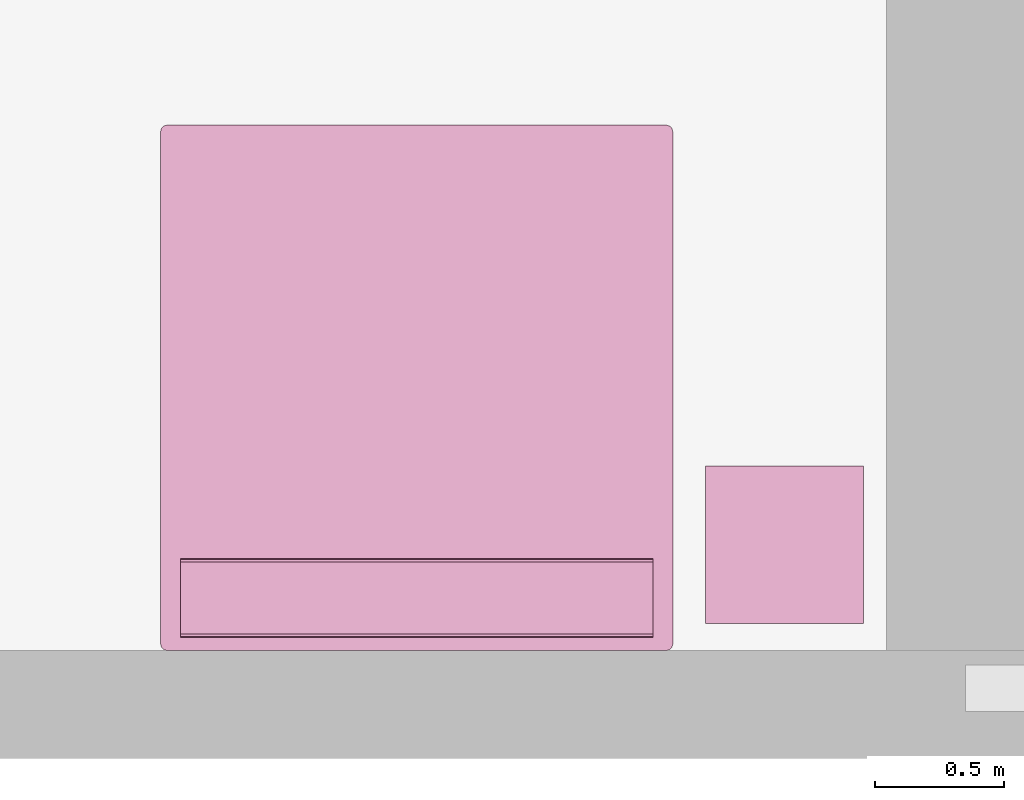
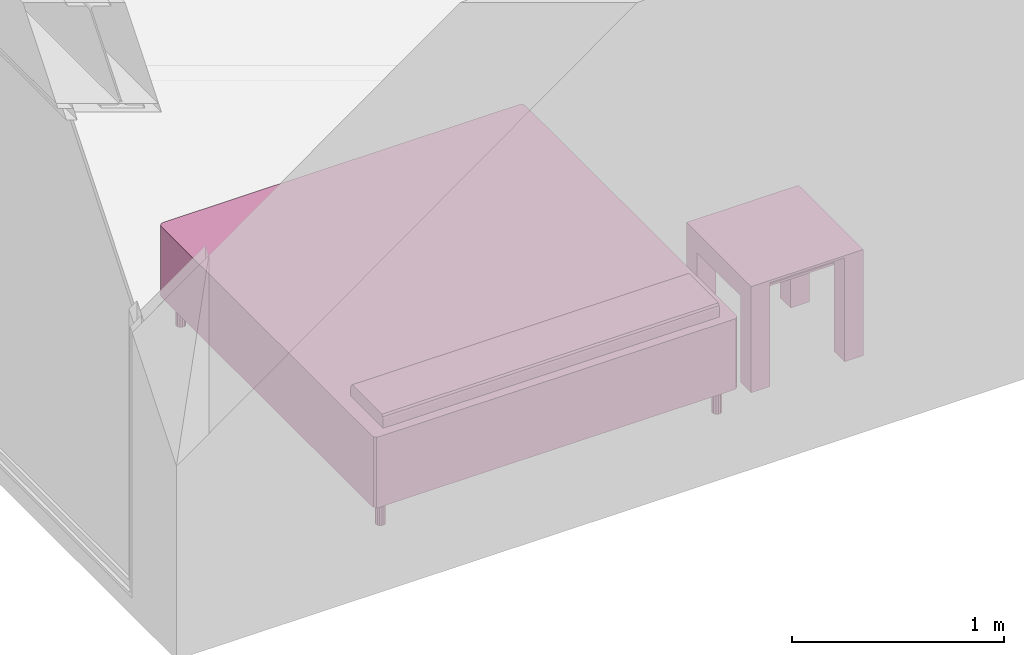
# One storey, part 6 of 12: 2 furnishings.
"""IFC2X3 building model written with IfcOpenShell, lengths in metres."""

import ifcopenshell
import ifcopenshell.guid

model = None  # the IFC model being written
_history = None  # IfcOwnerHistory: only IFC2X3 demands one
_inside = {}  # id of a spatial element -> (the spatial element, [elements in it])
_under = {}  # id of a project, library or spatial element -> (it, [spatial elements below it])
_declared = {}  # id of a project -> (the project, [libraries it declares])
_typed = {}  # id of a type object -> (the type object, [elements of that type])
_made_of = {}  # id of a material, layer set ... -> (it, [elements and type objects made of it])


def new_model(schema):
    """Start an empty IFC model of exactly this schema.

    Asked for "IFC4X3", IfcOpenShell would pick the latest addendum, in which some entities
    have other attributes; the version numbers below select the first issue.
    IFC2X3 requires an IfcOwnerHistory on every rooted entity: one is made here for all.
    """
    global model, _history
    if schema == "IFC4X3":
        model = ifcopenshell.file(schema_version=(4, 3, 0, 0))
    else:
        model = ifcopenshell.file(schema=schema)
    _inside.clear()
    _under.clear()
    _declared.clear()
    _typed.clear()
    _made_of.clear()
    _history = None
    if model.schema == "IFC2X3":
        org = make("IfcOrganization", Name="unknown")
        user = make(
            "IfcPersonAndOrganization",
            ThePerson=make("IfcPerson", FamilyName="unknown"),
            TheOrganization=org,
        )
        app = make(
            "IfcApplication",
            ApplicationDeveloper=org,
            Version="unknown",
            ApplicationFullName="unknown",
            ApplicationIdentifier="unknown",
        )
        _history = make(
            "IfcOwnerHistory",
            OwningUser=user,
            OwningApplication=app,
            ChangeAction="ADDED",
            CreationDate=0,
        )
    return model


def make(cls, **values):
    """One entity of the class cls with the attributes given. An attribute that is None is left unset."""
    return model.create_entity(
        cls, **{name: value for name, value in values.items() if value is not None}
    )


def entity(cls, *values):
    """Any entity or typed value of the class cls, its attributes in the order of the schema. None: left unset."""
    e = model.create_entity(cls)
    for i, value in enumerate(values):
        if value is not None:
            e[i] = value
    return e


def rooted(cls, **values):
    """An entity with a GlobalId (a new one), such as an element, a storey or a relation."""
    return make(cls, GlobalId=ifcopenshell.guid.new(), OwnerHistory=_history, **values)


def si_unit(unit_type, name, prefix=None):
    """IfcSIUnit, for example si_unit("LENGTHUNIT", "METRE", prefix="MILLI")."""
    return make("IfcSIUnit", UnitType=unit_type, Prefix=prefix, Name=name)


def converted_unit(unit_type, name, factor, base, dimensions=None, offset=None):
    """IfcConversionBasedUnit, such as the inch: factor (a typed value) times the base unit."""
    return make(
        "IfcConversionBasedUnit"
        if offset is None
        else "IfcConversionBasedUnitWithOffset",
        ConversionOffset=offset,
        Dimensions=None
        if dimensions is None
        else entity("IfcDimensionalExponents", *dimensions),
        UnitType=unit_type,
        Name=name,
        ConversionFactor=make(
            "IfcMeasureWithUnit", ValueComponent=factor, UnitComponent=base
        ),
    )


def assignment(units):
    """IfcUnitAssignment: the units of a project."""
    return None if units is None else make("IfcUnitAssignment", Units=units)


def point(xyz):
    """IfcCartesianPoint."""
    return None if xyz is None else make("IfcCartesianPoint", Coordinates=xyz)


def direction(xyz):
    """IfcDirection."""
    return None if xyz is None else make("IfcDirection", DirectionRatios=xyz)


def frame(location, z_axis=None, x_axis=None):
    """IfcAxis2Placement3D, a coordinate frame: its origin and axes. An axis left out is left unset."""
    return make(
        "IfcAxis2Placement3D",
        Location=point(location),
        Axis=direction(z_axis),
        RefDirection=direction(x_axis),
    )


def frame_2d(location, x_axis=None):
    """IfcAxis2Placement2D, a coordinate frame in the plane: its origin and x axis."""
    return make(
        "IfcAxis2Placement2D", Location=point(location), RefDirection=direction(x_axis)
    )


def origin():
    """The frame at (0, 0, 0) with its axes left unset."""
    return frame((0.0, 0.0, 0.0))


def origin_2d_with_axis():
    """The frame at (0, 0) in the plane with the x axis (1, 0) written out."""
    return frame_2d((0.0, 0.0), x_axis=(1.0, 0.0))


def place(relative_to, where):
    """IfcLocalPlacement: puts the frame where relative to a parent placement (None: the world)."""
    return make(
        "IfcLocalPlacement", PlacementRelTo=relative_to, RelativePlacement=where
    )


def context(
    kind, dimensions, precision=None, world=None, true_north=None, identifier=None
):
    """IfcGeometricRepresentationContext, for example the 3D "Model" context."""
    return make(
        "IfcGeometricRepresentationContext",
        ContextIdentifier=identifier,
        ContextType=kind,
        CoordinateSpaceDimension=dimensions,
        Precision=precision,
        WorldCoordinateSystem=world,
        TrueNorth=true_north,
    )


def project(units=None, contexts=None):
    """IfcProject with its units and contexts."""
    return rooted(
        "IfcProject",
        Name="project",
        RepresentationContexts=contexts,
        UnitsInContext=assignment(units),
    )


def spatial(cls, under=None, at=None, **own):
    """A site, building, storey or space (cls), placed at a placement, below another one or the project."""
    s = rooted(cls, ObjectPlacement=at, **own)
    if under is not None:
        _under.setdefault(under.id(), (under, []))[1].append(s)
    return s


def polyline(points):
    """IfcPolyline through the points."""
    return make("IfcPolyline", Points=[point(p) for p in points])


def profile(cls, at=None, kind="AREA", **sizes):
    """A parametric profile (cls). Its sizes go by their IFC names, for example OverallWidth=200.0."""
    return make(cls, ProfileType=kind, Position=at, **sizes)


def rectangle(**sizes):
    """IfcRectangleProfileDef."""
    return profile("IfcRectangleProfileDef", **sizes)


def outline(outer, holes=None, kind="AREA"):
    """IfcArbitraryClosedProfileDef: a profile drawn as a closed curve; with holes, ...WithVoids."""
    if holes is None:
        return make("IfcArbitraryClosedProfileDef", ProfileType=kind, OuterCurve=outer)
    return make(
        "IfcArbitraryProfileDefWithVoids",
        ProfileType=kind,
        OuterCurve=outer,
        InnerCurves=holes,
    )


def extrude(swept, where, along, depth):
    """IfcExtrudedAreaSolid: the profile swept, set in the frame where, extruded along a direction by depth."""
    return make(
        "IfcExtrudedAreaSolid",
        SweptArea=swept,
        Position=where,
        ExtrudedDirection=direction(along),
        Depth=depth,
    )


def faces_of(points, faces, orient=None, outer=None):
    """IfcFace entities. A face is a list of loops; a loop is a list of indices into points, from 0.

    orient and outer hold one flag for each loop. By default every Orientation is true, the
    first loop of a face is its IfcFaceOuterBound and the others are IfcFaceBound.
    """
    made = []
    for i, loops in enumerate(faces):
        bounds = []
        for j, loop in enumerate(loops):
            is_outer = j == 0 if outer is None else outer[i][j]
            bounds.append(
                make(
                    "IfcFaceOuterBound" if is_outer else "IfcFaceBound",
                    Bound=make("IfcPolyLoop", Polygon=[points[k] for k in loop]),
                    Orientation=True if orient is None else orient[i][j],
                )
            )
        made.append(make("IfcFace", Bounds=bounds))
    return made


def face_set(faces, orient=None, outer=None):
    """The faces of one IfcConnectedFaceSet. surface_model builds it on its shared points."""
    return ("IfcConnectedFaceSet", faces, orient, outer)


def surface_model(cls, points, shells):
    """IfcFaceBasedSurfaceModel or IfcShellBasedSurfaceModel (cls): surfaces that need not close."""
    shared = [point(p) for p in points]
    made = [make(c, CfsFaces=faces_of(shared, fs, o, b)) for c, fs, o, b in shells]
    if cls == "IfcFaceBasedSurfaceModel":
        return make(cls, FbsmFaces=made)
    return make(cls, SbsmBoundary=made)


def shape(context_of_items, identifier, shape_type, items):
    """IfcShapeRepresentation: the items that make up one representation, for example the "Body"."""
    return make(
        "IfcShapeRepresentation",
        ContextOfItems=context_of_items,
        RepresentationIdentifier=identifier,
        RepresentationType=shape_type,
        Items=items,
    )


def source(mapping_origin, context_of_items, identifier, shape_type, items):
    """IfcRepresentationMap: a shape defined once, which mapped items show again and again."""
    return make(
        "IfcRepresentationMap",
        MappingOrigin=mapping_origin,
        MappedRepresentation=shape(context_of_items, identifier, shape_type, items),
    )


def transform(
    local_origin,
    x_axis=None,
    y_axis=None,
    z_axis=None,
    scale=None,
    scale2=None,
    scale3=None,
    uniform=True,
):
    """IfcCartesianTransformationOperator3D, or its non-uniform kind. x_axis, y_axis, z_axis: its Axis1, 2, 3."""
    if uniform:
        return make(
            "IfcCartesianTransformationOperator3D",
            Axis1=direction(x_axis),
            Axis2=direction(y_axis),
            LocalOrigin=point(local_origin),
            Scale=scale,
            Axis3=direction(z_axis),
        )
    return make(
        "IfcCartesianTransformationOperator3DnonUniform",
        Axis1=direction(x_axis),
        Axis2=direction(y_axis),
        LocalOrigin=point(local_origin),
        Scale=scale,
        Axis3=direction(z_axis),
        Scale2=scale2,
        Scale3=scale3,
    )


def mapped(mapping_source, mapping_target):
    """IfcMappedItem: shows the shape of a source again, moved by a transform."""
    return make(
        "IfcMappedItem", MappingSource=mapping_source, MappingTarget=mapping_target
    )


def made_of(thing, what):
    """Note that an element or type object is made of a material, layer set ...; save() writes the relation."""
    if what is not None:
        _made_of.setdefault(what.id(), (what, []))[1].append(thing)
    return thing


def type_object(cls, material=None, **own):
    """A type object (cls), such as IfcWallType, which elements share."""
    return made_of(rooted(cls, **own), material)


def type_shapes(of_type, sources):
    """Give a type object the sources (RepresentationMaps) that its elements show as mapped items."""
    of_type.RepresentationMaps = sources


def element(
    cls,
    number,
    at=None,
    inside=None,
    cuts=None,
    type_object=None,
    material=None,
    context=None,
    identifier="Body",
    shape_type=None,
    held_by="IfcProductDefinitionShape",
    body=None,
    shapes=None,
    **own,
):
    """One element of the class cls, such as IfcWall. Its Tag is "e" and its number.

    at: its placement. inside: the storey or other place that contains it. cuts: it is an
    opening in that element (IfcRelVoidsElement). A single representation is given by context,
    identifier, shape_type and body (its items); several are given by shapes. held_by: the class
    of the entity that holds the representations. save() writes the other relations.
    """
    e = rooted(cls, Tag="e%d" % number, ObjectPlacement=at, **own)
    if body is not None:
        shapes = [shape(context, identifier, shape_type, body)]
    if shapes is not None:
        e.Representation = make(held_by, Representations=shapes)
    if inside is not None:
        _inside.setdefault(inside.id(), (inside, []))[1].append(e)
    if cuts is not None:
        rooted(
            "IfcRelVoidsElement", RelatingBuildingElement=cuts, RelatedOpeningElement=e
        )
    if type_object is not None:
        _typed.setdefault(type_object.id(), (type_object, []))[1].append(e)
    return made_of(e, material)


def aggregate(whole, parts):
    """IfcRelAggregates: a whole, such as a stair, and the parts it consists of."""
    return rooted("IfcRelAggregates", RelatingObject=whole, RelatedObjects=parts)


def save(model, path):
    """Write the relations noted so far, then the file.

    IfcRelAggregates (storeys below a building ...), IfcRelContainedInSpatialStructure (elements
    in a storey), IfcRelDefinesByType, IfcRelAssociatesMaterial and IfcRelDeclares: one each for
    every whole, place, type object, material and project.
    """
    for whole, parts in _under.values():
        aggregate(whole, parts)
    for where, things in _inside.values():
        rooted(
            "IfcRelContainedInSpatialStructure",
            RelatedElements=things,
            RelatingStructure=where,
        )
    for kind, things in _typed.values():
        rooted("IfcRelDefinesByType", RelatedObjects=things, RelatingType=kind)
    for what, things in _made_of.values():
        rooted("IfcRelAssociatesMaterial", RelatedObjects=things, RelatingMaterial=what)
    for by, libraries in _declared.values():
        rooted("IfcRelDeclares", RelatingContext=by, RelatedDefinitions=libraries)
    model.write(path)


model = new_model("IFC2X3")

# Units and contexts
model_context = context("Model", 3, precision=1e-09, world=origin())
plan_context = context("Plan", 3, precision=1e-09, world=origin())
ifc_project = project(units=[si_unit("LENGTHUNIT", "METRE"), si_unit("AREAUNIT", "SQUARE_METRE"), si_unit("VOLUMEUNIT", "CUBIC_METRE"), converted_unit("PLANEANGLEUNIT", "DEGREE", entity("IfcRatioMeasure", 0.0174532925199433), si_unit("PLANEANGLEUNIT", "RADIAN"), dimensions=[0, 0, 0, 0, 0, 0, 0]), si_unit("TIMEUNIT", "SECOND")], contexts=[model_context, plan_context])

# Site, building, storey, space
site_placement = place(None, origin())
site = spatial("IfcSite", under=ifc_project, at=site_placement, CompositionType="ELEMENT")
building_placement = place(site_placement, origin())
building = spatial("IfcBuilding", under=site, at=building_placement, CompositionType="ELEMENT")
storey_placement = place(building_placement, frame((0.0, 0.0, 3.10000000000038)))
storey = spatial("IfcBuildingStorey", under=building, at=storey_placement, Name="Level 2", CompositionType="ELEMENT", Elevation=3.10000000000038)
space_placement = place(storey_placement, origin())
space = spatial("IfcSpace", under=storey, at=space_placement, CompositionType="ELEMENT", InteriorOrExteriorSpace="INTERNAL")

# Furnishings
furniture_type_1 = type_object("IfcFurnitureType", Name="0610 x 0610 x 0610mm", AssemblyPlace="NOTDEFINED")
shared_shape_1 = source(origin(), model_context, "Body", "SweptSolid", [
    extrude(rectangle(XDim=0.406799999999999, YDim=0.406799999999999, at=origin_2d_with_axis()), frame((0.0182657666726316, 0.0952110778022263, 0.4957), z_axis=(0.0, 0.0, 1.0), x_axis=(-1.0, 0.0, 0.0)), (0.0, 0.0, 1.0), 0.0127),
    extrude(outline(polyline([(-0.273249999999994, -0.305), (0.324049999999978, -0.305), (0.324049999999978, 0.304999999999998), (-0.273249999999993, 0.304999999999999), (-0.273249999999993, 0.203400000000001), (0.222450000000009, 0.203400000000001), (0.222450000000009, -0.2034), (-0.273249999999994, -0.2034), (-0.273249999999994, -0.305)])), frame((0.221665766672633, 0.0952110778022354, 0.273249999999992), z_axis=(1.0, 0.0, 0.0), x_axis=(0.0, 0.0, 1.0)), (0.0, 0.0, 1.0), 0.1016),
    extrude(outline(polyline([(-0.305000000000004, -0.324050000000025), (0.304999999999994, -0.324050000000025), (0.304999999999994, 0.273250000000011), (0.203400000000004, 0.273250000000011), (0.203400000000004, -0.222449999999996), (-0.203399999999995, -0.222449999999996), (-0.203399999999995, 0.273250000000011), (-0.305000000000004, 0.273250000000011), (-0.305000000000004, -0.324050000000025)])), frame((-0.286734233327367, 0.0952110778022256, 0.273250000000008), z_axis=(1.0, 0.0, 0.0), x_axis=(0.0, -1.0, 0.0)), (0.0, 0.0, 1.0), 0.1016),
    extrude(rectangle(XDim=0.406799999999999, YDim=0.406799999999999, at=origin_2d_with_axis()), frame((0.0182657666726316, 0.0952110778022259, 0.5973), z_axis=(0.0, 0.0, 1.0), x_axis=(-1.0, 0.0, 0.0)), (0.0, 0.0, 1.0), 0.0127),
    extrude(outline(polyline([(-0.305, -0.305000000000023), (0.305, -0.305000000000023), (0.305, 0.305000000000023), (-0.305, 0.305000000000023), (-0.305, -0.305000000000023)]), holes=[polyline([(-0.203399999999998, -0.203399999999975), (-0.203399999999998, 0.203400000000025), (0.203400000000001, 0.203400000000025), (0.203400000000001, -0.203399999999975), (-0.203399999999998, -0.203399999999975)])]), frame((0.0182657666726332, 0.0952110778022508, 0.5973), z_axis=(0.0, 0.0, 1.0), x_axis=(-1.0, 0.0, 0.0)), (0.0, 0.0, 1.0), 0.0127),
])
type_shapes(furniture_type_1, [shared_shape_1])
furnishing_1_placement = place(space_placement, frame((3.71173423332735, -17.0692110778022, 0.0189999999998181)))
element("IfcFurnishingElement", 1, at=furnishing_1_placement, inside=space, type_object=furniture_type_1, Name="M_Table-Coffee:0610 x 0610 x 0610mm:0610 x 0610 x 0610mm", ObjectType="0610 x 0610 x 0610mm", context=model_context, shape_type="MappedRepresentation", body=[
    mapped(shared_shape_1, transform((0.0, 0.0, 0.0), scale=1.0)),
])
furniture_type_2 = type_object("IfcFurnitureType", Name="1981 x 2032mm - King", AssemblyPlace="NOTDEFINED")
shared_shape_2 = source(origin(), model_context, "Body", "SurfaceModel", [
    surface_model("IfcFaceBasedSurfaceModel", [(0.00159527223592605, 0.0269952722359239, 0.3556), (0.00159527223591658, 2.00819527223598, 0.3556), (0.0049982269797851, 2.02089527223596, 0.3556), (0.0142952722358911, 2.03019231749206, 0.3556), (0.0269952722358653, 2.03359527223592, 0.3556), (1.95719527223595, 2.03359527223593, 0.3556), (1.96989527223593, 2.03019231749206, 0.3556), (1.97919231749203, 2.02089527223596, 0.3556), (1.98259527223589, 2.00819527223598, 0.3556), (1.9825952722359, 0.0269952722358916, 0.3556), (1.97919231749203, 0.0142952722359042, 0.3556), (1.96989527223591, 0.00499822697978862, 0.3556), (1.95719527223593, 0.00159527223592321, 0.3556), (0.0269952722359262, 0.00159527223592348, 0.3556), (0.0142952722359261, 0.0049982269797989, 0.3556), (0.00499822697980134, 0.0142952722359238, 0.3556), (0.00159527223592578, 0.0269952722359234, 0.1524), (0.00159527223591658, 2.00819527223598, 0.1524), (0.0049982269797851, 2.02089527223596, 0.1524), (0.0142952722358911, 2.03019231749206, 0.1524), (0.0269952722358655, 2.03359527223593, 0.1524), (1.95719527223595, 2.03359527223593, 0.1524), (1.96989527223593, 2.03019231749206, 0.1524), (1.97919231749203, 2.02089527223596, 0.1524), (1.9825952722359, 2.00819527223598, 0.1524), (1.9825952722359, 0.0269952722358916, 0.1524), (1.97919231749203, 0.0142952722359042, 0.1524), (1.96989527223591, 0.00499822697978862, 0.1524), (1.95719527223593, 0.00159527223591685, 0.1524), (0.0269952722359262, 0.00159527223592348, 0.1524), (0.0142952722359261, 0.0049982269797989, 0.1524), (0.00499822697980134, 0.0142952722359238, 0.1524), (0.00355996307916939, 0.0196629166603088, 0.152400001883507), (0.00329675246030092, 0.0206452682614327, 0.355599999427795), (0.00964672770351171, 0.00964673981070518, 0.355599999427795), (0.00964672770351171, 0.00964673981070518, 0.152400001883507), (0.0206452570855617, 0.00329676410183311, 0.152400001883507), (0.0196629054844379, 0.00355997472070157, 0.355599999427795), (1.96452760696411, 0.00355997472070157, 0.152400001883507), (1.96354532241821, 0.00329676410183311, 0.355599999427795), (1.97454369068146, 0.00964673981070518, 0.355599999427795), (1.97454369068146, 0.00964673981070518, 0.152400001883507), (1.98089373111725, 0.0206452682614327, 0.152400001883507), (1.98063051700592, 0.0196629166603088, 0.355599999427795), (1.98089373111725, 2.01454520225525, 0.355599999427795), (1.98089373111725, 2.01454520225525, 0.152400001883507), (1.97454369068146, 2.02554392814636, 0.355599999427795), (1.97454369068146, 2.02554392814636, 0.152400001883507), (1.96354532241821, 2.03189373016357, 0.152400001883507), (1.96452760696411, 2.03163051605225, 0.355599999427795), (0.0196629054844379, 2.03163051605225, 0.152400001883507), (0.0206452570855617, 2.03189373016357, 0.355599999427795), (0.00964672770351171, 2.02554392814636, 0.355599999427795), (0.00964672770351171, 2.02554392814636, 0.152400001883507), (0.00329675246030092, 2.01454520225525, 0.152400001883507), (0.00355996307916939, 2.01552772521973, 0.355599999427795), (0.0777952722359236, 1.67799527223594, 0.5588), (0.0777952722359236, 1.67799527223594, 0.6096), (0.0777952722359236, 1.68139822697982, 0.6223), (0.0777952722359236, 1.69069527223594, 0.631597045256125), (0.0777952722359236, 1.70339527223594, 0.635), (0.0777952722359242, 1.95739527223594, 0.635), (0.0777952722359242, 1.97009527223594, 0.631597045256125), (0.0777952722359242, 1.97939231749207, 0.6223), (0.0777952722359242, 1.98279527223594, 0.6096), (0.0777952722359242, 1.98279527223594, 0.5588), (1.90639527223589, 1.67799527223594, 0.5588), (1.9063952722359, 1.98279527223594, 0.5588), (1.9063952722359, 1.98279527223594, 0.6096), (1.9063952722359, 1.97939231749206, 0.6223), (1.9063952722359, 1.97009527223594, 0.631597045256125), (1.9063952722359, 1.95739527223594, 0.635), (1.90639527223589, 1.70339527223594, 0.635), (1.90639527223589, 1.69069527223594, 0.631597045256125), (1.90639527223589, 1.68139822697981, 0.6223), (1.90639527223589, 1.67799527223594, 0.6096), (0.0777952596545219, 1.67974185943603, 0.616118371486664), (1.90639531612396, 1.67969679832458, 0.615949988365173), (0.0777952596545219, 1.68604671955109, 0.626948475837708), (1.90639531612396, 1.68604671955109, 0.626948475837708), (1.90639531612396, 1.69704532623291, 0.633298575878143), (0.0777952596545219, 1.69687688350677, 0.633253455162048), (1.90639531612396, 1.96391367912293, 0.633253455162048), (0.0777952596545219, 1.96374523639679, 0.633298575878143), (0.0777952596545219, 1.97474384307861, 0.626948475837708), (1.90639531612396, 1.97474384307861, 0.626948475837708), (1.90639531612396, 1.98109376430511, 0.615949988365173), (0.0777952596545219, 1.98104870319366, 0.616118371486664), (0.1031952722359, 1.95739527223592, 0.1524), (0.100679881480621, 1.94637462526233, 0.1524), (0.0936319132031119, 1.93753675258123, 0.1524), (0.0834473039583905, 1.9326321032665, 0.1524), (0.0721432405134099, 1.9326321032665, 0.1524), (0.0619586312686885, 1.93753675258123, 0.1524), (0.0549106629911789, 1.94637462526233, 0.1524), (0.0523952722359002, 1.95739527223592, 0.1524), (0.0549106629911787, 1.9684159192095, 0.1524), (0.0619586312686883, 1.97725379189061, 0.1524), (0.0721432405134097, 1.98215844120534, 0.1524), (0.0834473039583904, 1.98215844120534, 0.1524), (0.0936319132031118, 1.97725379189061, 0.1524), (0.100679881480621, 1.9684159192095, 0.1524), (1.93179527223592, 1.95739527223595, 0.1524), (1.92927988148063, 1.94637462526236, 0.1524), (1.92223191320312, 1.93753675258125, 0.1524), (1.91204730395839, 1.93263210326651, 0.1524), (1.9007432405134, 1.93263210326651, 0.1524), (1.89055863126867, 1.93753675258125, 0.1524), (1.88351066299115, 1.94637462526236, 0.1524), (1.88099527223587, 1.95739527223595, 0.1524), (1.88351066299115, 1.96841591920955, 0.1524), (1.89055863126866, 1.97725379189066, 0.1524), (1.9007432405134, 1.98215844120539, 0.1524), (1.91204730395839, 1.98215844120539, 0.1524), (1.92223191320312, 1.97725379189066, 0.1524), (1.92927988148063, 1.96841591920955, 0.1524), (1.93179527223592, 0.0777952722359584, 0.1524), (1.92927988148064, 0.0667746252623723, 0.1524), (1.92223191320313, 0.0579367525812703, 0.1524), (1.91204730395841, 0.0530321032665399, 0.1524), (1.90074324051343, 0.0530321032665397, 0.1524), (1.8905586312687, 0.0579367525812703, 0.1524), (1.8835106629912, 0.0667746252623721, 0.1524), (1.88099527223592, 0.0777952722359579, 0.1524), (1.8835106629912, 0.0888159192095439, 0.1524), (1.8905586312687, 0.097653791890646, 0.1524), (1.90074324051343, 0.102558441205376, 0.1524), (1.91204730395841, 0.102558441205376, 0.1524), (1.92223191320313, 0.097653791890646, 0.1524), (1.92927988148064, 0.0888159192095439, 0.1524), (0.103195272235929, 0.0777952722359205, 0.1524), (0.10067988148065, 0.0667746252623334, 0.1524), (0.0936319132031394, 0.05793675258123, 0.1524), (0.0834473039584167, 0.053032103266499, 0.1524), (0.0721432405134344, 0.053032103266499, 0.1524), (0.0619586312687115, 0.0579367525812297, 0.1524), (0.0549106629912009, 0.0667746252623328, 0.1524), (0.0523952722359219, 0.0777952722359205, 0.1524), (0.0549106629912009, 0.0888159192095077, 0.1524), (0.0619586312687115, 0.0976537918906108, 0.1524), (0.0721432405134342, 0.102558441205342, 0.1524), (0.0834473039584165, 0.102558441205342, 0.1524), (0.0936319132031394, 0.0976537918906108, 0.1524), (0.10067988148065, 0.0888159192095077, 0.1524), (0.1031952722359, 1.95739527223592, 0.0), (0.100679881480621, 1.94637462526233, 0.0), (0.0936319132031119, 1.93753675258123, 0.0), (0.0834473039583905, 1.9326321032665, 0.0), (0.0721432405134099, 1.9326321032665, 0.0), (0.0619586312686885, 1.93753675258123, 0.0), (0.0549106629911789, 1.94637462526233, 0.0), (0.0523952722359002, 1.95739527223592, 0.0), (0.0549106629911787, 1.9684159192095, 0.0), (0.0619586312686883, 1.97725379189061, 0.0), (0.0721432405134097, 1.98215844120534, 0.0), (0.0834473039583904, 1.98215844120534, 0.0), (0.0936319132031118, 1.97725379189061, 0.0), (0.100679881480621, 1.9684159192095, 0.0), (1.93179527223592, 1.95739527223595, 0.0), (1.92927988148063, 1.94637462526236, 0.0), (1.92223191320312, 1.93753675258125, 0.0), (1.91204730395839, 1.93263210326651, 0.0), (1.9007432405134, 1.93263210326651, 0.0), (1.89055863126867, 1.93753675258125, 0.0), (1.88351066299115, 1.94637462526236, 0.0), (1.88099527223587, 1.95739527223595, 0.0), (1.88351066299115, 1.96841591920955, 0.0), (1.89055863126866, 1.97725379189066, 0.0), (1.9007432405134, 1.98215844120539, 0.0), (1.91204730395839, 1.98215844120539, 0.0), (1.92223191320312, 1.97725379189066, 0.0), (1.92927988148063, 1.96841591920955, 0.0), (1.93179527223592, 0.0777952722359579, 0.0), (1.92927988148064, 0.0667746252623723, 0.0), (1.92223191320313, 0.0579367525812703, 0.0), (1.91204730395841, 0.0530321032665399, 0.0), (1.90074324051343, 0.0530321032665397, 0.0), (1.8905586312687, 0.0579367525812703, 0.0), (1.8835106629912, 0.0667746252623721, 0.0), (1.88099527223592, 0.0777952722359579, 0.0), (1.8835106629912, 0.0888159192095439, 0.0), (1.8905586312687, 0.097653791890646, 0.0), (1.90074324051343, 0.102558441205376, 0.0), (1.91204730395841, 0.102558441205376, 0.0), (1.92223191320313, 0.097653791890646, 0.0), (1.92927988148064, 0.0888159192095439, 0.0), (0.103195272235929, 0.0777952722359202, 0.0), (0.10067988148065, 0.0667746252623334, 0.0), (0.0936319132031394, 0.05793675258123, 0.0), (0.0834473039584167, 0.053032103266499, 0.0), (0.0721432405134344, 0.053032103266499, 0.0), (0.0619586312687115, 0.0579367525812297, 0.0), (0.0549106629912009, 0.0667746252623328, 0.0), (0.0523952722359219, 0.0777952722359205, 0.0), (0.0549106629912009, 0.0888159192095077, 0.0), (0.0619586312687115, 0.0976537918906108, 0.0), (0.0721432405134342, 0.102558441205342, 0.0), (0.0834473039584165, 0.102558441205342, 0.0), (0.0936319132031394, 0.0976537918906108, 0.0), (0.10067988148065, 0.0888159192095077, 0.0), (0.0536529794335365, 1.95188498497009, 0.152400001883507), (0.0584346652030945, 1.94195568561554, 0.0), (0.0584346652030945, 1.94195568561554, 0.152400001883507), (0.102065727114677, 1.95244646072388, 0.152400001883507), (0.101937606930733, 1.95188498497009, 0.0), (0.06705092638731, 1.93508446216583, 0.0), (0.06705092638731, 1.93508446216583, 0.152400001883507), (0.0535247921943665, 1.95244646072388, 0.0), (0.0777952596545219, 1.93263208866119, 0.152400001883507), (0.0777952596545219, 1.93263208866119, 0.0), (0.0885395854711533, 1.93508446216583, 0.0), (0.0885395854711533, 1.93508446216583, 0.152400001883507), (0.0971559211611748, 1.94195568561554, 0.0), (0.0971559211611748, 1.94195568561554, 0.152400001883507), (0.102065727114677, 1.9623441696167, 0.0), (0.101937606930733, 1.96290552616119, 0.152400001883507), (0.0971559211611748, 1.97283482551575, 0.0), (0.0971559211611748, 1.97283482551575, 0.152400001883507), (0.0885395854711533, 1.97970616817474, 0.152400001883507), (0.0885395854711533, 1.97970616817474, 0.0), (0.0777952596545219, 1.98215842247009, 0.152400001883507), (0.0777952596545219, 1.98215842247009, 0.0), (0.06705092638731, 1.97970616817474, 0.152400001883507), (0.06705092638731, 1.97970616817474, 0.0), (0.0535247921943665, 1.9623441696167, 0.152400001883507), (0.0584346652030945, 1.97283482551575, 0.152400001883507), (0.0584346652030945, 1.97283482551575, 0.0), (0.0536529794335365, 1.96290552616119, 0.0), (1.88225305080414, 1.95188498497009, 0.152400001883507), (1.88703465461731, 1.94195568561554, 0.152400001883507), (1.88703465461731, 1.94195568561554, 0.0), (1.93053758144379, 1.95188498497009, 0.0), (1.93066573143005, 1.95244646072388, 0.152400001883507), (1.89565098285675, 1.93508446216583, 0.0), (1.89565098285675, 1.93508446216583, 0.152400001883507), (1.88212478160858, 1.95244646072388, 0.0), (1.90639531612396, 1.93263208866119, 0.152400001883507), (1.90639531612396, 1.93263208866119, 0.0), (1.91713964939117, 1.93508446216583, 0.0), (1.91713964939117, 1.93508446216583, 0.152400001883507), (1.92575585842133, 1.94195568561554, 0.0), (1.92575585842133, 1.94195568561554, 0.152400001883507), (1.93066573143005, 1.9623441696167, 0.0), (1.93053758144379, 1.96290552616119, 0.152400001883507), (1.92575585842133, 1.97283482551575, 0.152400001883507), (1.92575585842133, 1.97283482551575, 0.0), (1.91713964939117, 1.97970616817474, 0.152400001883507), (1.91713964939117, 1.97970616817474, 0.0), (1.90639531612396, 1.98215842247009, 0.152400001883507), (1.90639531612396, 1.98215842247009, 0.0), (1.89565098285675, 1.97970616817474, 0.152400001883507), (1.89565098285675, 1.97970616817474, 0.0), (1.88212478160858, 1.9623441696167, 0.152400001883507), (1.88703465461731, 1.97283482551575, 0.0), (1.88703465461731, 1.97283482551575, 0.152400001883507), (1.88225305080414, 1.96290552616119, 0.0), (1.88225305080414, 0.072284922003746, 0.152400001883507), (1.88703465461731, 0.0623556599020958, 0.0), (1.88703465461731, 0.0623556599020958, 0.152400001883507), (1.93053758144379, 0.072284922003746, 0.0), (1.93066573143005, 0.0728464424610138, 0.152400001883507), (1.89565098285675, 0.0554844215512276, 0.152400001883507), (1.89565098285675, 0.0554844215512276, 0.0), (1.88212478160858, 0.0728464424610138, 0.0), (1.90639531612396, 0.0530321002006531, 0.0), (1.90639531612396, 0.0530321002006531, 0.152400001883507), (1.91713964939117, 0.0554844215512276, 0.152400001883507), (1.91713964939117, 0.0554844215512276, 0.0), (1.92575585842133, 0.0623556599020958, 0.0), (1.92575585842133, 0.0623556599020958, 0.152400001883507), (1.93066573143005, 0.0827440917491913, 0.0), (1.93053758144379, 0.083305612206459, 0.152400001883507), (1.92575585842133, 0.0932348817586899, 0.152400001883507), (1.92575585842133, 0.0932348817586899, 0.0), (1.91713964939117, 0.100106120109558, 0.0), (1.91713964939117, 0.100106120109558, 0.152400001883507), (1.90639531612396, 0.102558441460133, 0.0), (1.90639531612396, 0.102558441460133, 0.152400001883507), (1.89565098285675, 0.100106120109558, 0.0), (1.89565098285675, 0.100106120109558, 0.152400001883507), (1.88212478160858, 0.0827440917491913, 0.152400001883507), (1.88703465461731, 0.0932348817586899, 0.0), (1.88703465461731, 0.0932348817586899, 0.152400001883507), (1.88225305080414, 0.083305612206459, 0.0), (0.0536529794335365, 0.072284922003746, 0.152400001883507), (0.0584346652030945, 0.0623556599020958, 0.152400001883507), (0.0584346652030945, 0.0623556599020958, 0.0), (0.102065727114677, 0.0728464424610138, 0.152400001883507), (0.101937606930733, 0.072284922003746, 0.0), (0.06705092638731, 0.0554844215512276, 0.152400001883507), (0.06705092638731, 0.0554844215512276, 0.0), (0.0535247921943665, 0.0728464424610138, 0.0), (0.0777952596545219, 0.0530321002006531, 0.0), (0.0777952596545219, 0.0530321002006531, 0.152400001883507), (0.0885395854711533, 0.0554844215512276, 0.152400001883507), (0.0885395854711533, 0.0554844215512276, 0.0), (0.0971559211611748, 0.0623556599020958, 0.152400001883507), (0.0971559211611748, 0.0623556599020958, 0.0), (0.102065727114677, 0.0827440917491913, 0.0), (0.101937606930733, 0.083305612206459, 0.152400001883507), (0.0971559211611748, 0.0932348817586899, 0.0), (0.0971559211611748, 0.0932348817586899, 0.152400001883507), (0.0885395854711533, 0.100106120109558, 0.0), (0.0885395854711533, 0.100106120109558, 0.152400001883507), (0.0777952596545219, 0.102558441460133, 0.0), (0.0777952596545219, 0.102558441460133, 0.152400001883507), (0.06705092638731, 0.100106120109558, 0.0), (0.06705092638731, 0.100106120109558, 0.152400001883507), (0.0535247921943665, 0.0827440917491913, 0.152400001883507), (0.0584346652030945, 0.0932348817586899, 0.152400001883507), (0.0584346652030945, 0.0932348817586899, 0.0), (0.0536529794335365, 0.083305612206459, 0.0), (0.0269952722358659, 2.03359527223593, 0.5588), (1.95719527223595, 2.03359527223593, 0.5588), (1.96989527223593, 2.03019231749206, 0.5588), (1.97919231749203, 2.02089527223596, 0.5588), (1.98259527223589, 2.00819527223598, 0.5588), (1.9825952722359, 0.026995272235891, 0.5588), (1.97919231749203, 0.0142952722359034, 0.5588), (1.96989527223591, 0.0049982269797878, 0.5588), (1.95719527223593, 0.00159527223592307, 0.5588), (0.0269952722359262, 0.00159527223592335, 0.5588), (0.0142952722359259, 0.00499822697979863, 0.5588), (0.00499822697980093, 0.0142952722359237, 0.5588), (0.00159527223592551, 0.0269952722359238, 0.5588), (0.00159527223591603, 2.00819527223598, 0.5588), (0.00499822697978469, 2.02089527223596, 0.5588), (0.0142952722358911, 2.03019231749206, 0.5588), (0.0269952722358659, 2.03359527223592, 0.3556), (1.95719527223595, 2.03359527223593, 0.3556), (1.96989527223593, 2.03019231749206, 0.3556), (1.97919231749203, 2.02089527223596, 0.3556), (1.9825952722359, 2.00819527223598, 0.3556), (1.9825952722359, 0.0269952722358912, 0.3556), (1.97919231749203, 0.0142952722359034, 0.3556), (1.96989527223591, 0.0049982269797878, 0.3556), (1.95719527223593, 0.00159527223591603, 0.3556), (0.0269952722359262, 0.00159527223592335, 0.3556), (0.0142952722359259, 0.00499822697979863, 0.3556), (0.00499822697980093, 0.0142952722359237, 0.3556), (0.00159527223592578, 0.0269952722359241, 0.3556), (0.00159527223591603, 2.00819527223598, 0.3556), (0.00499822697978469, 2.02089527223596, 0.3556), (0.0142952722358911, 2.03019231749206, 0.3556), (0.0196629054844379, 2.03163051605225, 0.355599999427795), (0.0206452570855617, 2.03189373016357, 0.558800041675568), (0.00964672770351171, 2.02554392814636, 0.558800041675568), (0.00964672770351171, 2.02554392814636, 0.355599999427795), (0.00329675246030092, 2.01454520225525, 0.355599999427795), (0.00355996307916939, 2.01552772521973, 0.558800041675568), (0.00355996307916939, 0.0196629166603088, 0.355599999427795), (0.00329675246030092, 0.0206452682614327, 0.558800041675568), (0.00964672770351171, 0.00964673981070518, 0.558800041675568), (0.00964672770351171, 0.00964673981070518, 0.355599999427795), (0.0206452570855617, 0.00329676410183311, 0.355599999427795), (0.0196629054844379, 0.00355997472070157, 0.558800041675568), (1.96452760696411, 0.00355997472070157, 0.355599999427795), (1.96354532241821, 0.00329676410183311, 0.558800041675568), (1.97454369068146, 0.00964673981070518, 0.558800041675568), (1.97454369068146, 0.00964673981070518, 0.355599999427795), (1.98089373111725, 0.0206452682614327, 0.355599999427795), (1.98063051700592, 0.0196629166603088, 0.558800041675568), (1.98063051700592, 2.01552772521973, 0.355599999427795), (1.98089373111725, 2.01454520225525, 0.558800041675568), (1.97454369068146, 2.02554392814636, 0.558800041675568), (1.97454369068146, 2.02554392814636, 0.355599999427795), (1.96354532241821, 2.03189373016357, 0.355599999427795), (1.96452760696411, 2.03163051605225, 0.558800041675568)], [face_set([[[0, 1, 2, 3, 4, 5, 6, 7, 8, 9, 10, 11, 12, 13, 14, 15]], [[16, 17, 18, 19, 20, 21, 22, 23, 24, 25, 26, 27, 28, 29, 30, 31]], [[15, 32, 31]], [[32, 15, 33]], [[33, 0, 16]], [[34, 35, 30, 14]], [[16, 32, 33]], [[36, 29, 13]], [[37, 30, 36]], [[35, 34, 15, 31]], [[30, 37, 14]], [[13, 37, 36]], [[12, 28, 29, 13]], [[11, 38, 27]], [[38, 11, 39]], [[39, 12, 28]], [[40, 41, 26, 10]], [[28, 38, 39]], [[42, 25, 9]], [[43, 26, 42]], [[41, 40, 11, 27]], [[26, 43, 10]], [[9, 43, 42]], [[8, 9, 25, 24]], [[44, 8, 24, 45]], [[44, 45, 23, 7]], [[46, 47, 22, 6]], [[48, 21, 5]], [[5, 49, 48]], [[22, 49, 6]], [[47, 46, 7, 23]], [[49, 22, 48]], [[4, 5, 21, 20]], [[3, 50, 19]], [[50, 3, 51]], [[51, 4, 20]], [[52, 53, 18, 2]], [[20, 50, 51]], [[54, 17, 1]], [[55, 18, 54]], [[53, 52, 3, 19]], [[18, 55, 2]], [[1, 55, 54]], [[0, 1, 17, 16]]]), face_set([[[56, 57, 58, 59, 60, 61, 62, 63, 64, 65]], [[66, 67, 68, 69, 70, 71, 72, 73, 74, 75]], [[57, 56, 66, 75]], [[74, 76, 77]], [[77, 57, 75]], [[57, 77, 76]], [[78, 79, 73, 59]], [[80, 72, 60]], [[60, 81, 80]], [[73, 81, 59]], [[79, 78, 58, 74]], [[81, 73, 80]], [[74, 58, 76]], [[61, 71, 72, 60]], [[62, 82, 70]], [[82, 62, 83]], [[83, 61, 71]], [[84, 85, 69, 63]], [[71, 82, 83]], [[86, 68, 64]], [[87, 69, 86]], [[85, 84, 62, 70]], [[69, 87, 63]], [[64, 87, 86]], [[65, 67, 68, 64]], [[56, 65, 67, 66]]]), face_set([[[88, 89, 90, 91, 92, 93, 94, 95, 96, 97, 98, 99, 100, 101]], [[102, 103, 104, 105, 106, 107, 108, 109, 110, 111, 112, 113, 114, 115]], [[116, 117, 118, 119, 120, 121, 122, 123, 124, 125, 126, 127, 128, 129]], [[130, 131, 132, 133, 134, 135, 136, 137, 138, 139, 140, 141, 142, 143]], [[144, 145, 146, 147, 148, 149, 150, 151, 152, 153, 154, 155, 156, 157]], [[158, 159, 160, 161, 162, 163, 164, 165, 166, 167, 168, 169, 170, 171]], [[172, 173, 174, 175, 176, 177, 178, 179, 180, 181, 182, 183, 184, 185]], [[186, 187, 188, 189, 190, 191, 192, 193, 194, 195, 196, 197, 198, 199]], [[94, 200, 150]], [[201, 149, 202, 94]], [[203, 204, 89]], [[92, 148, 205, 206]], [[150, 200, 207]], [[200, 95, 207]], [[94, 150, 201]], [[206, 205, 149, 93]], [[149, 93, 202]], [[92, 208, 147, 209]], [[95, 151, 207]], [[90, 146, 210, 211]], [[145, 212, 90, 213]], [[147, 91, 211, 210]], [[213, 89, 145]], [[204, 203, 144]], [[212, 146, 90]], [[89, 204, 145]], [[208, 91, 147]], [[92, 209, 148]], [[203, 88, 144]], [[214, 144, 88]], [[215, 214, 88]], [[100, 156, 216, 217]], [[157, 101, 217, 216]], [[218, 219, 155, 99]], [[214, 215, 157]], [[157, 215, 101]], [[100, 156, 219, 218]], [[220, 221, 154, 98]], [[222, 223, 153, 97]], [[151, 95, 224]], [[225, 226, 152, 96]], [[226, 225, 97, 153]], [[151, 224, 227]], [[98, 154, 223, 222]], [[152, 227, 96]], [[221, 220, 99, 155]], [[96, 227, 224]], [[164, 228, 108]], [[108, 229, 163, 230]], [[103, 231, 232]], [[106, 162, 233, 234]], [[235, 228, 164]], [[235, 109, 228]], [[230, 164, 108]], [[234, 233, 163, 107]], [[229, 107, 163]], [[106, 236, 161, 237]], [[235, 165, 109]], [[104, 160, 238, 239]], [[240, 241, 104, 160]], [[241, 240, 159, 103]], [[161, 105, 239, 238]], [[158, 232, 231]], [[159, 231, 103]], [[236, 105, 161]], [[106, 237, 162]], [[158, 102, 232]], [[102, 158, 242]], [[102, 242, 243]], [[244, 245, 170, 114]], [[245, 244, 115, 171]], [[246, 247, 169, 113]], [[171, 243, 242]], [[115, 243, 171]], [[114, 170, 247, 246]], [[248, 249, 168, 112]], [[250, 251, 167, 111]], [[252, 109, 165]], [[110, 166, 253, 254]], [[167, 111, 254, 253]], [[255, 252, 165]], [[112, 168, 251, 250]], [[110, 255, 166]], [[249, 248, 113, 169]], [[252, 255, 110]], [[178, 256, 122]], [[121, 177, 257, 258]], [[117, 259, 260]], [[261, 262, 176, 120]], [[263, 256, 178]], [[263, 123, 256]], [[178, 122, 258, 257]], [[121, 177, 262, 261]], [[264, 175, 265, 120]], [[263, 179, 123]], [[266, 267, 174, 118]], [[268, 269, 118, 174]], [[269, 268, 173, 117]], [[267, 266, 119, 175]], [[172, 260, 259]], [[173, 259, 117]], [[175, 119, 265]], [[176, 264, 120]], [[172, 116, 260]], [[116, 172, 270]], [[116, 270, 271]], [[272, 273, 184, 128]], [[273, 272, 129, 185]], [[127, 183, 274, 275]], [[185, 271, 270]], [[129, 271, 185]], [[275, 274, 184, 128]], [[126, 182, 276, 277]], [[125, 181, 278, 279]], [[280, 123, 179]], [[124, 180, 281, 282]], [[181, 125, 282, 281]], [[283, 280, 179]], [[279, 278, 182, 126]], [[124, 283, 180]], [[183, 127, 277, 276]], [[280, 283, 124]], [[136, 284, 192]], [[285, 286, 191, 135]], [[287, 288, 131]], [[289, 290, 190, 134]], [[192, 284, 291]], [[284, 137, 291]], [[286, 285, 136, 192]], [[135, 191, 290, 289]], [[292, 189, 293, 134]], [[137, 193, 291]], [[294, 295, 188, 132]], [[188, 132, 296, 297]], [[131, 187, 297, 296]], [[295, 294, 133, 189]], [[288, 287, 186]], [[131, 288, 187]], [[189, 133, 293]], [[190, 292, 134]], [[287, 130, 186]], [[298, 186, 130]], [[299, 298, 130]], [[142, 198, 300, 301]], [[199, 143, 301, 300]], [[141, 197, 302, 303]], [[298, 299, 199]], [[199, 299, 143]], [[303, 302, 198, 142]], [[140, 196, 304, 305]], [[139, 195, 306, 307]], [[193, 137, 308]], [[309, 310, 194, 138]], [[310, 309, 139, 195]], [[193, 308, 311]], [[307, 306, 196, 140]], [[194, 311, 138]], [[197, 141, 305, 304]], [[138, 311, 308]]]), face_set([[[312, 313, 314, 315, 316, 317, 318, 319, 320, 321, 322, 323, 324, 325, 326, 327]], [[328, 329, 330, 331, 332, 333, 334, 335, 336, 337, 338, 339, 340, 341, 342, 343]], [[327, 344, 343]], [[344, 327, 345]], [[345, 312, 328]], [[346, 347, 342, 326]], [[328, 344, 345]], [[348, 341, 325]], [[349, 342, 348]], [[347, 346, 327, 343]], [[342, 349, 326]], [[325, 349, 348]], [[324, 325, 341, 340]], [[323, 350, 339]], [[350, 323, 351]], [[351, 324, 340]], [[352, 353, 338, 322]], [[340, 350, 351]], [[354, 337, 321]], [[355, 338, 354]], [[353, 352, 323, 339]], [[338, 355, 322]], [[321, 355, 354]], [[320, 336, 337, 321]], [[319, 356, 335]], [[356, 319, 357]], [[357, 320, 336]], [[358, 359, 334, 318]], [[336, 356, 357]], [[360, 333, 317]], [[361, 334, 360]], [[359, 358, 319, 335]], [[334, 361, 318]], [[317, 361, 360]], [[316, 317, 333, 332]], [[315, 362, 331]], [[362, 315, 363]], [[363, 316, 332]], [[364, 365, 330, 314]], [[332, 362, 363]], [[366, 329, 313]], [[367, 330, 366]], [[365, 364, 315, 331]], [[330, 367, 314]], [[313, 367, 366]], [[312, 313, 329, 328]]])]),
])
type_shapes(furniture_type_2, [shared_shape_2])
furnishing_2_placement = place(space_placement, frame((3.29959527223589, -15.3494047277641, 0.0), z_axis=(0.0, 0.0, 1.0), x_axis=(-1.0, 0.0, 0.0)))
element("IfcFurnishingElement", 2, at=furnishing_2_placement, inside=space, type_object=furniture_type_2, Name="M_Bed-Standard:1981 x 2032mm - King:1981 x 2032mm - King", ObjectType="1981 x 2032mm - King", context=model_context, shape_type="MappedRepresentation", body=[
    mapped(shared_shape_2, transform((0.0, 0.0, 0.0), scale=1.0)),
])

save(model, "model.ifc")
